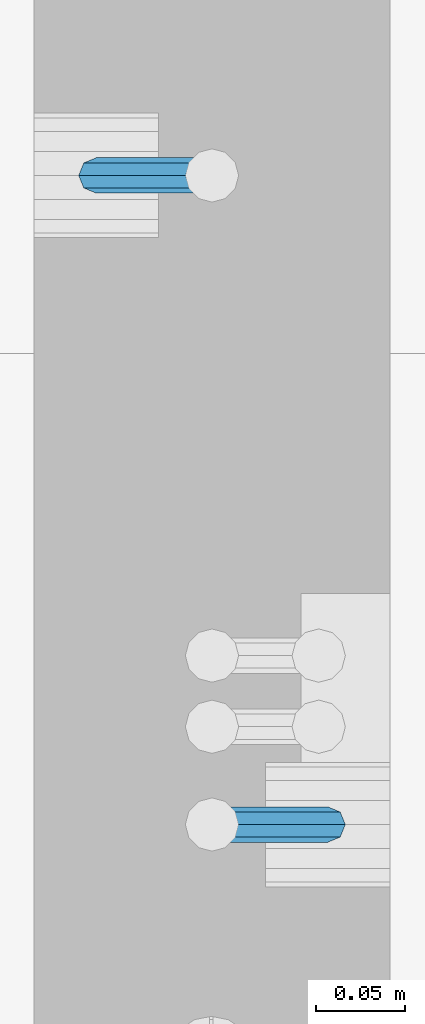
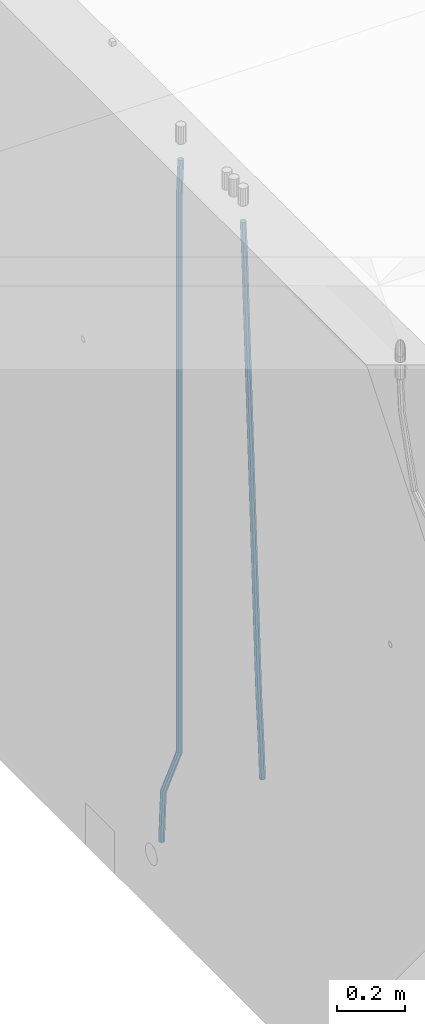
# One storey, part 111 of 350: 2 beams, 1 element without a shape of its own.
"""IFC2X3 building model written with IfcOpenShell, lengths in millimetres."""

from ifc_helpers import new_model, si_unit, frame, origin_with_axes, place, context, subcontext, project, spatial, faceted_brep, material, type_object, element, aggregate, save


model = new_model("IFC2X3")

# Units and contexts
model_context = context("Model", 3, precision=1e-05, world=origin_with_axes())
body_context = subcontext(model_context, "Body", "Model", "MODEL_VIEW")
ifc_project = project(units=[si_unit("LENGTHUNIT", "METRE", prefix="MILLI"), si_unit("AREAUNIT", "SQUARE_METRE"), si_unit("VOLUMEUNIT", "CUBIC_METRE"), si_unit("MASSUNIT", "GRAM", prefix="KILO"), si_unit("TIMEUNIT", "SECOND"), si_unit("PLANEANGLEUNIT", "RADIAN"), si_unit("SOLIDANGLEUNIT", "STERADIAN"), si_unit("THERMODYNAMICTEMPERATUREUNIT", "DEGREE_CELSIUS"), si_unit("LUMINOUSINTENSITYUNIT", "LUMEN")], contexts=[model_context])

# Site, building, storey
site_placement = place(None, origin_with_axes())
site = spatial("IfcSite", under=ifc_project, at=site_placement, CompositionType="ELEMENT")
building_placement = place(site_placement, origin_with_axes())
building = spatial("IfcBuilding", under=site, at=building_placement, CompositionType="ELEMENT")
storey_placement = place(building_placement, origin_with_axes())
storey = spatial("IfcBuildingStorey", under=building, at=storey_placement, Name="2", CompositionType="ELEMENT", Elevation=0.0)

# Assembly, beams
assembly_placement = place(storey_placement, origin_with_axes())
assembly = element("IfcElementAssembly", 1, at=assembly_placement, inside=storey, AssemblyPlace="NOTDEFINED", PredefinedType="REINFORCEMENT_UNIT")
ifc_material = material()
beam_type = type_object("IfcBeamType", Name="D20", PredefinedType="NOTDEFINED")
beam_1_placement = place(assembly_placement, frame((28544.9999977209, 10199.9999999961, 84990.0), z_axis=(0.999642804629538, 0.000205762999925497, -0.0267249099901003), x_axis=(0.0267249109941254, -4.30000210532798e-08, 0.999642825779465)))
beam_1 = element("IfcBeam", 2, at=beam_1_placement, type_object=beam_type, material=ifc_material, Name="JM20", ObjectType="D20", context=body_context, shape_type="Brep", body=[
    faceted_brep([(0.0, -10.0, 0.0), (-4.19531716033816e-08, -7.07106781186667, -7.07106781187031), (60.4266690400545, -7.0710677960451, -7.07106780570757), (60.4266690441291, -9.99999998418934, 6.15546014159918e-09), (0.0, 0.0, -10.0), (60.426669036824, 1.58106558956206e-08, -9.99999999384454), (4.196772351861e-08, 7.07106781186303, -7.07106781186667), (60.4266690363438, 7.07106782768096, -7.07106780570757), (0.0, 10.0, 0.0), (60.4266690388904, 10.0000000158179, 6.15182216279209e-09), (4.196772351861e-08, 7.07106781185939, 7.07106781185939), (60.4266690429649, 7.07106782768096, 7.07106781802577), (0.0, 0.0, 10.0), (60.4266690461809, 1.58179318532348e-08, 10.0000000061555), (-4.19531716033816e-08, -7.07106781187031, 7.07106781185939), (60.4266690466611, -7.07106779605238, 7.07106781802213), (61.0378400410118, -7.07106779588503, -7.07106780564936), (60.991799419251, -9.99999998403655, 6.21366780251265e-09), (61.0569027789461, 1.5985278878361e-08, -9.99999999378269), (61.0378209396877, 7.07106782784831, -7.07106780564936), (60.9917724058905, 10.0000000159635, 6.21366780251265e-09), (60.9457317841297, 7.07106782781193, 7.0710678180767), (60.9266690461809, 1.59488990902901e-08, 10.0000000062028), (60.9457508854539, -7.07106779591413, 7.0710678180767), (61.6489592143771, -7.07106614513759, -7.06310863441468), (61.5568818710308, -9.9999984576425, 0.00735959856683621), (61.6870830769039, 1.71821739058942e-06, -9.99179257185824), (61.6489210170112, 7.07106947854481, -7.06310888312146), (61.556827851804, 10.0000015422847, 0.00735924683976918), (61.4647505084577, 7.07106922979438, 7.07782747982128), (61.4266266459163, 1.36643211590126e-06, 10.0065114172685), (61.464788705809, -7.07106639389531, 7.07782772852806), (174.687552722433, -7.07076080651314, -5.59090229463982), (174.595475379101, -9.99969311901441, 1.47956593833806), (174.725676584974, 0.000307056843666942, -8.51958623208702), (174.687514525082, 7.07137481716563, -5.59090254334296), (174.595421359889, 10.0003068809128, 1.47956558661826), (174.503344016543, 7.07137456841338, 8.55003381959614), (174.465220154001, 0.000306705052935285, 11.4787177570433), (174.503382213894, -7.07076105526721, 8.55003406830292), (178.411119022741, -7.07075074845488, -5.54240684062097), (176.984006760467, -9.99968666713903, 1.51067399562089), (179.002004930298, 0.000318608017551014, -8.46389164578432), (178.410531532325, 7.07138487374141, -5.54241424327847), (176.983175923553, 10.0003133306891, 1.51066352668204), (175.556063661294, 7.07137741200677, 8.56374436293117), (174.965177753722, 0.000308055534333107, 11.4852291681018), (175.55665115171, -7.07075821018952, 8.56375176559231), (181.860590403347, -7.07046206550149, -4.13939404019766), (179.196716291408, -9.99950148759854, 2.41065531246204), (182.963549066117, 0.0006501458465209, -6.85260211220157), (181.859494053802, 7.07167351410681, -4.13960841250446), (179.195165819008, 10.0004984500029, 2.41035214424483), (176.53129170707, 7.07145902790762, 8.9604014969118), (175.4283330443, 0.000346816555975238, 11.6736095689084), (176.532388056628, -7.07067655170249, 8.96061586921132), (301.519716318551, -7.06044790802298, 44.5298850528161), (298.855842206613, -9.98948733012003, 51.0799344054794), (302.622674981321, 0.0106643033268483, 41.8166769808158), (301.518619968992, 7.08168767158713, 44.5296706805166), (298.854291734213, 10.0105126074832, 51.0796312372659), (296.190417622274, 7.08147318538795, 57.6296805899292), (295.087458959504, 0.0103609740363027, 60.3428886619331), (296.191513971818, -7.06066239422216, 57.6298949622287), (302.550983896435, -7.0603616022272, 44.9493352968675), (301.259218966865, -9.98928619382241, 52.0574663188745), (303.085830271899, 0.0107030643484904, 42.0050573816261), (302.550452340292, 7.08177402464935, 44.9493506445069), (301.258467232954, 10.0107138106268, 52.0574880237145), (299.966702303384, 7.08178921903163, 59.1656190457179), (299.43185592792, 0.0107245524523023, 62.1098969609629), (299.967233859526, -7.06034640784492, 59.1656036980785), (303.66389269162, -7.06036773843152, 44.9195805511263), (303.852861191248, -9.98930049429327, 51.9881226626203), (303.585651664005, 0.0107003085049655, 41.9916941496158), (303.663970641253, 7.08176788508536, 44.9195796030108), (303.852971428671, 10.0106995054011, 51.9881213217814), (304.041939928298, 7.08176674954302, 59.056663433279), (304.120180955913, 0.0106987026065326, 61.9845498347931), (304.04186197868, -7.06036887397568, 59.0566643813945), (2293.89747825902, -7.07134121643867, -8.29133355361773), (2294.08644675865, -10.0002739723022, -1.22279144212007), (2293.81923723139, -0.000273169503998361, -11.2192199551246), (2293.89755620864, 7.07079440707639, -8.29133450173322), (2294.08655699606, 9.99972602739399, -1.222792782959), (2294.27552549569, 7.07079327153588, 5.84574932853866), (2294.3537665233, -0.00027477540061227, 8.77363573004914), (2294.27544754607, -7.07134235197918, 5.84575027666142), (2294.69287336971, -7.07134560198028, -8.31259924887127), (2294.7212373514, -10.0002774723216, -1.23976321264126), (2294.71933078663, -0.000278132318271673, -11.2432848695171), (2294.78511120615, 7.07078951339463, -8.31506418505887), (2294.85168135064, 9.99972180875739, -1.24324915883699), (2294.88004533235, 7.07078993841787, 5.82958687739301), (2294.85358791542, -0.000277531249594176, 8.76027249803883), (2294.7878074959, -7.07134517696068, 5.83205181358426), (2295.48841462671, -7.08171948304698, -8.30201138058692), (2295.3561445809, -10.0085566810103, -1.23131322459085), (2295.61958972551, -0.0120175349929923, -11.2313033123282), (2295.67282928347, 7.05921364392088, -8.30324953435411), (2295.61694628959, 9.98974273175736, -1.23306423844406), (2295.48467624377, 7.06290553379404, 5.83763391755565), (2295.35350114497, -0.00679641425995214, 8.76692584929697), (2295.30026158702, -7.07802759317201, 5.83887207132284), (2317.19468265201, -7.36476984771616, -8.01312239505205), (2317.0624126062, -10.2916070456795, -0.942424239052343), (2317.32585775082, -0.295067899662172, -10.9424143267934), (2317.37909730877, 6.7761632792517, -8.0143605488156), (2317.32321431489, 9.70669236708818, -0.944175252901914), (2317.19094426908, 6.77985516912668, 6.12652290309416), (2317.05976917029, -0.289846778929132, 9.05581483483547), (2317.00652961232, -7.36107795784301, 6.12776105686498), (2317.83013419241, -7.37305615423429, -8.00466516275992), (2317.72250117944, -10.3002146198196, -0.933639112190576), (2317.90419002608, -0.302609369304264, -10.9347172954986), (2317.90128777748, 6.76935390039216, -8.00741070951335), (2317.82312754443, 9.70017348407237, -0.937521901640139), (2317.71549453147, 6.77301501848888, 6.13350414892557), (2317.64143869778, -0.297431766442969, 9.06355628166421), (2317.64434094641, -7.36939503613939, 6.13624969567536), (2318.46563955581, -7.37117997047972, -7.99640310650284), (2318.38264551188, -10.2982460556286, -0.925049637477059), (2318.48257153788, -0.300911365524371, -10.9272150971265), (2318.42352293266, 6.77089230007186, -8.0006556940134), (2318.32308361224, 9.70166434944622, -0.931063704414555), (2318.24008956832, 6.77459826429731, 6.14028976460395), (2318.22315758624, -0.295670340658035, 9.07110175523485), (2318.28220619148, -7.36747400625609, 6.14454235212179), (2418.48642551948, -7.07291710988466, -6.69903265976973), (2418.40343147556, -9.99998319503538, 0.372320809256053), (2418.50335750156, -0.00264850492931146, -9.62984465039699), (2418.44430889633, 7.06915516067056, -6.70328524728757), (2418.3438695759, 9.9999272100431, 0.366306742314919), (2418.260875532, 7.07286112489419, 7.43766021133706), (2418.24394354991, 0.00259251993884391, 10.368472201968), (2418.30299215514, -7.06921114565921, 7.4419127988549)], [[[0, 1, 2, 3]], [[1, 4, 5, 2]], [[4, 6, 7, 5]], [[6, 8, 9, 7]], [[8, 10, 11, 9]], [[10, 12, 13, 11]], [[12, 14, 15, 13]], [[14, 0, 3, 15]], [[14, 12, 10, 8, 6, 4, 1, 0]], [[3, 2, 16, 17]], [[2, 5, 18, 16]], [[5, 7, 19, 18]], [[7, 9, 20, 19]], [[9, 11, 21, 20]], [[11, 13, 22, 21]], [[13, 15, 23, 22]], [[15, 3, 17, 23]], [[17, 16, 24, 25]], [[16, 18, 26, 24]], [[18, 19, 27, 26]], [[19, 20, 28, 27]], [[20, 21, 29, 28]], [[21, 22, 30, 29]], [[22, 23, 31, 30]], [[23, 17, 25, 31]], [[25, 24, 32, 33]], [[24, 26, 34, 32]], [[26, 27, 35, 34]], [[27, 28, 36, 35]], [[28, 29, 37, 36]], [[29, 30, 38, 37]], [[30, 31, 39, 38]], [[31, 25, 33, 39]], [[33, 32, 40, 41]], [[32, 34, 42, 40]], [[34, 35, 43, 42]], [[35, 36, 44, 43]], [[36, 37, 45, 44]], [[37, 38, 46, 45]], [[38, 39, 47, 46]], [[39, 33, 41, 47]], [[41, 40, 48, 49]], [[40, 42, 50, 48]], [[42, 43, 51, 50]], [[43, 44, 52, 51]], [[44, 45, 53, 52]], [[45, 46, 54, 53]], [[46, 47, 55, 54]], [[47, 41, 49, 55]], [[49, 48, 56, 57]], [[48, 50, 58, 56]], [[50, 51, 59, 58]], [[51, 52, 60, 59]], [[52, 53, 61, 60]], [[53, 54, 62, 61]], [[54, 55, 63, 62]], [[55, 49, 57, 63]], [[57, 56, 64, 65]], [[56, 58, 66, 64]], [[58, 59, 67, 66]], [[59, 60, 68, 67]], [[60, 61, 69, 68]], [[61, 62, 70, 69]], [[62, 63, 71, 70]], [[63, 57, 65, 71]], [[65, 64, 72, 73]], [[64, 66, 74, 72]], [[66, 67, 75, 74]], [[67, 68, 76, 75]], [[68, 69, 77, 76]], [[69, 70, 78, 77]], [[70, 71, 79, 78]], [[71, 65, 73, 79]], [[73, 72, 80, 81]], [[72, 74, 82, 80]], [[74, 75, 83, 82]], [[75, 76, 84, 83]], [[76, 77, 85, 84]], [[77, 78, 86, 85]], [[78, 79, 87, 86]], [[79, 73, 81, 87]], [[81, 80, 88, 89]], [[80, 82, 90, 88]], [[82, 83, 91, 90]], [[83, 84, 92, 91]], [[84, 85, 93, 92]], [[85, 86, 94, 93]], [[86, 87, 95, 94]], [[87, 81, 89, 95]], [[89, 88, 96, 97]], [[88, 90, 98, 96]], [[90, 91, 99, 98]], [[91, 92, 100, 99]], [[92, 93, 101, 100]], [[93, 94, 102, 101]], [[94, 95, 103, 102]], [[95, 89, 97, 103]], [[97, 96, 104, 105]], [[96, 98, 106, 104]], [[98, 99, 107, 106]], [[99, 100, 108, 107]], [[100, 101, 109, 108]], [[101, 102, 110, 109]], [[102, 103, 111, 110]], [[103, 97, 105, 111]], [[105, 104, 112, 113]], [[104, 106, 114, 112]], [[106, 107, 115, 114]], [[107, 108, 116, 115]], [[108, 109, 117, 116]], [[109, 110, 118, 117]], [[110, 111, 119, 118]], [[111, 105, 113, 119]], [[113, 112, 120, 121]], [[112, 114, 122, 120]], [[114, 115, 123, 122]], [[115, 116, 124, 123]], [[116, 117, 125, 124]], [[117, 118, 126, 125]], [[118, 119, 127, 126]], [[119, 113, 121, 127]], [[121, 120, 128, 129]], [[120, 122, 130, 128]], [[122, 123, 131, 130]], [[123, 124, 132, 131]], [[124, 125, 133, 132]], [[125, 126, 134, 133]], [[126, 127, 135, 134]], [[127, 121, 129, 135]], [[130, 131, 132, 133, 134, 135, 129, 128]]]),
])
beam_2_placement = place(assembly_placement, frame((28675.0000022791, 9835.00000000393, 85390.0), z_axis=(-0.999642804636942, -0.000205726999925762, -0.0267249099902983), x_axis=(-0.0267249099948371, 4.30000201934385e-08, 0.999642825806181)))
beam_2 = element("IfcBeam", 3, at=beam_2_placement, type_object=beam_type, material=ifc_material, Name="JM20", ObjectType="D20", context=body_context, shape_type="Brep", body=[
    faceted_brep([(0.0, -10.0, 0.0), (-4.19531716033816e-08, -7.07106781186667, -7.07106781187031), (60.4266690400545, -7.0710677960451, -7.07106780570757), (60.4266690441291, -9.99999998418934, 6.15546014159918e-09), (0.0, 0.0, -10.0), (60.426669036824, 1.58106558956206e-08, -9.99999999384454), (4.196772351861e-08, 7.07106781186303, -7.07106781186667), (60.4266690363438, 7.07106782768096, -7.07106780570757), (0.0, 10.0, 0.0), (60.4266690388904, 10.0000000158179, 6.15182216279209e-09), (4.196772351861e-08, 7.07106781185939, 7.07106781185939), (60.4266690429649, 7.07106782768096, 7.07106781802577), (0.0, 0.0, 10.0), (60.4266690461809, 1.58179318532348e-08, 10.0000000061555), (-4.19531716033816e-08, -7.07106781187031, 7.07106781185939), (60.4266690466611, -7.07106779605238, 7.07106781802213), (61.0378400410118, -7.07106779588503, -7.07106780564936), (60.991799419251, -9.99999998403655, 6.21366780251265e-09), (61.0569027789461, 1.5985278878361e-08, -9.99999999378269), (61.0378209396877, 7.07106782784831, -7.07106780564936), (60.9917724058905, 10.0000000159635, 6.21366780251265e-09), (60.9457317841297, 7.07106782781193, 7.0710678180767), (60.9266690461809, 1.59488990902901e-08, 10.0000000062028), (60.9457508854539, -7.07106779591413, 7.0710678180767), (61.6489592143771, -7.07106614513759, -7.06310863441468), (61.5568818710308, -9.9999984576425, 0.00735959856683621), (61.6870830769039, 1.71821739058942e-06, -9.99179257185824), (61.6489210170112, 7.07106947854481, -7.06310888312146), (61.556827851804, 10.0000015422847, 0.00735924683976918), (61.4647505084577, 7.07106922979438, 7.07782747982128), (61.4266266459163, 1.36643211590126e-06, 10.0065114172685), (61.464788705809, -7.07106639389531, 7.07782772852806), (176.543135720174, -7.07075579406956, -5.56673531796696), (176.451058376813, -9.99968810657447, 1.50373291501455), (176.581259582701, 0.000312069292704109, -8.49541925541052), (176.543097522794, 7.07137982961285, -5.56673556667374), (176.451004357587, 10.00031189336, 1.50373256329476), (176.35892701424, 7.07137958085514, 8.57420079627263), (176.320803151699, 0.000311717507429421, 11.5028847337162), (176.358965211621, -7.07075604281999, 8.57420104497578), (177.098753836006, -7.07075429323595, -5.55949898843028), (176.98362511232, -9.99968666800123, 1.510669025065), (177.146421932586, 0.000313595905026887, -8.48805862247536), (177.098706077581, 7.07138133041735, -5.55949936166144), (176.983557571715, 10.0003133318824, 1.51066849724157), (176.868428848029, 7.07138095712435, 8.58083651073321), (176.820760751449, 0.000313067976094317, 11.5093961447819), (176.868476606425, -7.07075466652896, 8.58083688396073), (177.654312950661, -7.07075204110879, -5.54863964998367), (177.516135294456, -9.99968450931192, 1.52107783331303), (177.711524267797, 0.000315886711177882, -8.47701274570863), (177.654255632195, 7.07138358250813, -5.54864021007961), (177.516054233929, 10.0003154905207, 1.5210770412159), (177.377876577739, 7.0713830223176, 8.59079452451624), (177.320665260588, 0.000315094497636892, 11.5191676202448), (177.377933896176, -7.07075260129932, 8.59079508461218), (299.529725389817, -7.0702579820354, -3.16637947698109), (299.391547733612, -9.99919045023489, 3.90333800631561), (299.586936706939, 0.000809945799119305, -6.09475257270606), (299.529668071336, 7.07187764158152, -3.16638003707703), (299.391466673056, 10.000809549605, 3.90333721422212), (299.253289016866, 7.07187708140191, 10.9730546975188), (299.196077699729, 0.000809153574664379, 13.9014277932438), (299.253346335332, -7.07025854221502, 10.9730552576111), (300.053154890193, -7.07025586015152, -3.15614816594825), (299.971788958996, -9.99918809853989, 3.91467979818117), (300.086841216093, 0.000811972313385922, -6.08498109724314), (300.053121210876, 7.07187976355999, -3.15614826397359), (299.971753863239, 10.0008119014747, 3.91467990454839), (299.890387932071, 7.07187966407218, 10.9855078686815), (299.856701606172, 0.000811831610917579, 13.9143407999763), (299.890421611388, -7.07025595963933, 10.9855079667068), (300.576681224076, -7.07025548863749, -3.15433176753868), (300.552150063115, -9.99918768617863, 3.91669348816504), (300.586838206684, 0.000812327129096957, -6.08324633496159), (300.57667118829, 7.07188013509221, -3.15433178353487), (300.552135870385, 10.0008123138141, 3.91669346554409), (300.527604709423, 7.07188011626931, 10.9877187212514), (300.517447726816, 0.000812300502730068, 13.9166332886707), (300.52761474521, -7.07025550746039, 10.9877187372476), (1894.37298527778, -7.06912446613933, 2.37541694085667), (1894.34845411681, -9.99805666368775, 9.44644219656402), (1894.3831422604, 0.00194334961997811, -0.553497626566241), (1894.37297524199, 7.07301115758673, 2.37541692486411), (1894.34843992408, 10.0019433363086, 9.44644217394307), (1894.32390876314, 7.07301113876019, 16.5174674296468), (1894.31375178052, 0.00194332300088718, 19.4463819970697), (1894.32391879891, -7.06912448496587, 16.5174674456393), (1894.94254953373, -7.06912406195261, 2.37739306992808), (1894.864138918, -9.99805629773618, 9.44823138841821), (1895.01321576146, 0.00194379674576339, -0.551311557919689), (1895.03474228333, 7.0730116272025, 2.3777129556911), (1894.99451915483, 10.0019437947958, 9.44868377519742), (1894.9161085391, 7.07301155900859, 16.5195220936839), (1894.8454423114, 0.0019437003065832, 19.4482267215244), (1894.8239157895, -7.06912413014652, 16.5192022079245), (1895.51201837322, -7.07655005247943, 2.3849721376755), (1895.3797373289, -10.0047798068154, 9.45509349396525), (1895.6431837092, -0.00627111456196872, -0.542927306803904), (1895.69639846191, 7.06438349486052, 2.38651894584837), (1895.64049015092, 9.99352020044898, 9.45728101107306), (1895.50820910657, 7.06529044610943, 16.5274023673664), (1895.37704377061, -0.00498849180803518, 19.4553018118422), (1895.3238290179, -7.07564310123053, 16.5258555591899), (1917.3375872656, -7.36115994941429, 2.67544890068893), (1917.20530622125, -10.2893897037538, 9.74557025698232), (1917.46875260158, -0.29088101150046, -0.252450543786836), (1917.52196735426, 6.77977359792203, 2.67699570887271), (1917.46605904329, 9.70891030351049, 9.74775777409013), (1917.33377799895, 6.78068054917094, 16.8178791303835), (1917.20261266298, -0.289598388742888, 19.7457785748593), (1917.1493979103, -7.36025299817265, 16.816332322207), (1917.97302879854, -7.36944623740055, 2.68390599981285), (1917.86539582294, -10.2979974076115, 9.75435539755927), (1918.04706999661, -0.298422389005282, -0.244753710507212), (1918.04414708749, 6.77296426705288, 2.68394540532245), (1917.9659722717, 9.70239133243012, 9.75441112535555), (1917.85833929609, 6.77384016221913, 16.824860523102), (1917.78429809801, -0.297183686179778, 19.753520233422), (1917.78722100714, -7.36857034223431, 16.8248211175924), (1918.60852415283, -7.36757026622581, 2.69216814523315), (1918.52554118163, -10.29602885028, 9.76294518245413), (1918.62543662851, -0.296724680512853, -0.237251666560041), (1918.56637150982, 6.77450246020453, 2.69070014292447), (1918.46592834221, 9.70388219950109, 9.76086911367383), (1918.38294537101, 6.7754236154542, 16.8316461508839), (1918.36603289531, -0.295421970262396, 19.7610659626844), (1918.42509801401, -7.36664911097978, 16.8331141531962), (2018.62930980593, -7.06930811566781, 3.98954616814444), (2018.54632683474, -9.99776669972198, 11.0603232053618), (2018.64622228162, 0.00153747004878824, 1.06012635634761), (2018.58715716293, 7.07276461076617, 3.98807816583212), (2018.4867139953, 10.0021443500664, 11.0582471365815), (2018.40373102411, 7.0736857660122, 18.1290241737915), (2018.38681854842, 0.00284018029924482, 21.0584439855957), (2018.44588366711, -7.06838696041814, 18.1304921761075)], [[[0, 1, 2, 3]], [[1, 4, 5, 2]], [[4, 6, 7, 5]], [[6, 8, 9, 7]], [[8, 10, 11, 9]], [[10, 12, 13, 11]], [[12, 14, 15, 13]], [[14, 0, 3, 15]], [[14, 12, 10, 8, 6, 4, 1, 0]], [[3, 2, 16, 17]], [[2, 5, 18, 16]], [[5, 7, 19, 18]], [[7, 9, 20, 19]], [[9, 11, 21, 20]], [[11, 13, 22, 21]], [[13, 15, 23, 22]], [[15, 3, 17, 23]], [[17, 16, 24, 25]], [[16, 18, 26, 24]], [[18, 19, 27, 26]], [[19, 20, 28, 27]], [[20, 21, 29, 28]], [[21, 22, 30, 29]], [[22, 23, 31, 30]], [[23, 17, 25, 31]], [[25, 24, 32, 33]], [[24, 26, 34, 32]], [[26, 27, 35, 34]], [[27, 28, 36, 35]], [[28, 29, 37, 36]], [[29, 30, 38, 37]], [[30, 31, 39, 38]], [[31, 25, 33, 39]], [[33, 32, 40, 41]], [[32, 34, 42, 40]], [[34, 35, 43, 42]], [[35, 36, 44, 43]], [[36, 37, 45, 44]], [[37, 38, 46, 45]], [[38, 39, 47, 46]], [[39, 33, 41, 47]], [[41, 40, 48, 49]], [[40, 42, 50, 48]], [[42, 43, 51, 50]], [[43, 44, 52, 51]], [[44, 45, 53, 52]], [[45, 46, 54, 53]], [[46, 47, 55, 54]], [[47, 41, 49, 55]], [[49, 48, 56, 57]], [[48, 50, 58, 56]], [[50, 51, 59, 58]], [[51, 52, 60, 59]], [[52, 53, 61, 60]], [[53, 54, 62, 61]], [[54, 55, 63, 62]], [[55, 49, 57, 63]], [[57, 56, 64, 65]], [[56, 58, 66, 64]], [[58, 59, 67, 66]], [[59, 60, 68, 67]], [[60, 61, 69, 68]], [[61, 62, 70, 69]], [[62, 63, 71, 70]], [[63, 57, 65, 71]], [[65, 64, 72, 73]], [[64, 66, 74, 72]], [[66, 67, 75, 74]], [[67, 68, 76, 75]], [[68, 69, 77, 76]], [[69, 70, 78, 77]], [[70, 71, 79, 78]], [[71, 65, 73, 79]], [[73, 72, 80, 81]], [[72, 74, 82, 80]], [[74, 75, 83, 82]], [[75, 76, 84, 83]], [[76, 77, 85, 84]], [[77, 78, 86, 85]], [[78, 79, 87, 86]], [[79, 73, 81, 87]], [[81, 80, 88, 89]], [[80, 82, 90, 88]], [[82, 83, 91, 90]], [[83, 84, 92, 91]], [[84, 85, 93, 92]], [[85, 86, 94, 93]], [[86, 87, 95, 94]], [[87, 81, 89, 95]], [[89, 88, 96, 97]], [[88, 90, 98, 96]], [[90, 91, 99, 98]], [[91, 92, 100, 99]], [[92, 93, 101, 100]], [[93, 94, 102, 101]], [[94, 95, 103, 102]], [[95, 89, 97, 103]], [[97, 96, 104, 105]], [[96, 98, 106, 104]], [[98, 99, 107, 106]], [[99, 100, 108, 107]], [[100, 101, 109, 108]], [[101, 102, 110, 109]], [[102, 103, 111, 110]], [[103, 97, 105, 111]], [[105, 104, 112, 113]], [[104, 106, 114, 112]], [[106, 107, 115, 114]], [[107, 108, 116, 115]], [[108, 109, 117, 116]], [[109, 110, 118, 117]], [[110, 111, 119, 118]], [[111, 105, 113, 119]], [[113, 112, 120, 121]], [[112, 114, 122, 120]], [[114, 115, 123, 122]], [[115, 116, 124, 123]], [[116, 117, 125, 124]], [[117, 118, 126, 125]], [[118, 119, 127, 126]], [[119, 113, 121, 127]], [[121, 120, 128, 129]], [[120, 122, 130, 128]], [[122, 123, 131, 130]], [[123, 124, 132, 131]], [[124, 125, 133, 132]], [[125, 126, 134, 133]], [[126, 127, 135, 134]], [[127, 121, 129, 135]], [[130, 131, 132, 133, 134, 135, 129, 128]]]),
])
aggregate(assembly, [beam_1, beam_2])

save(model, "model.ifc")
